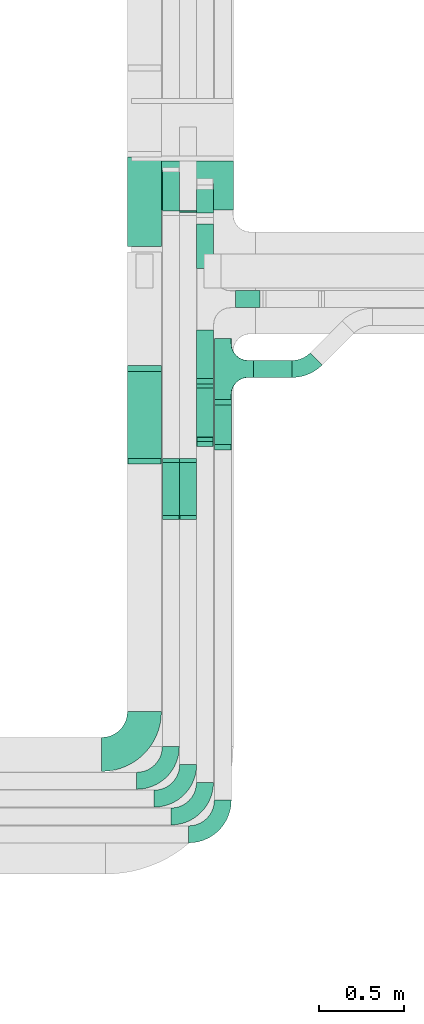
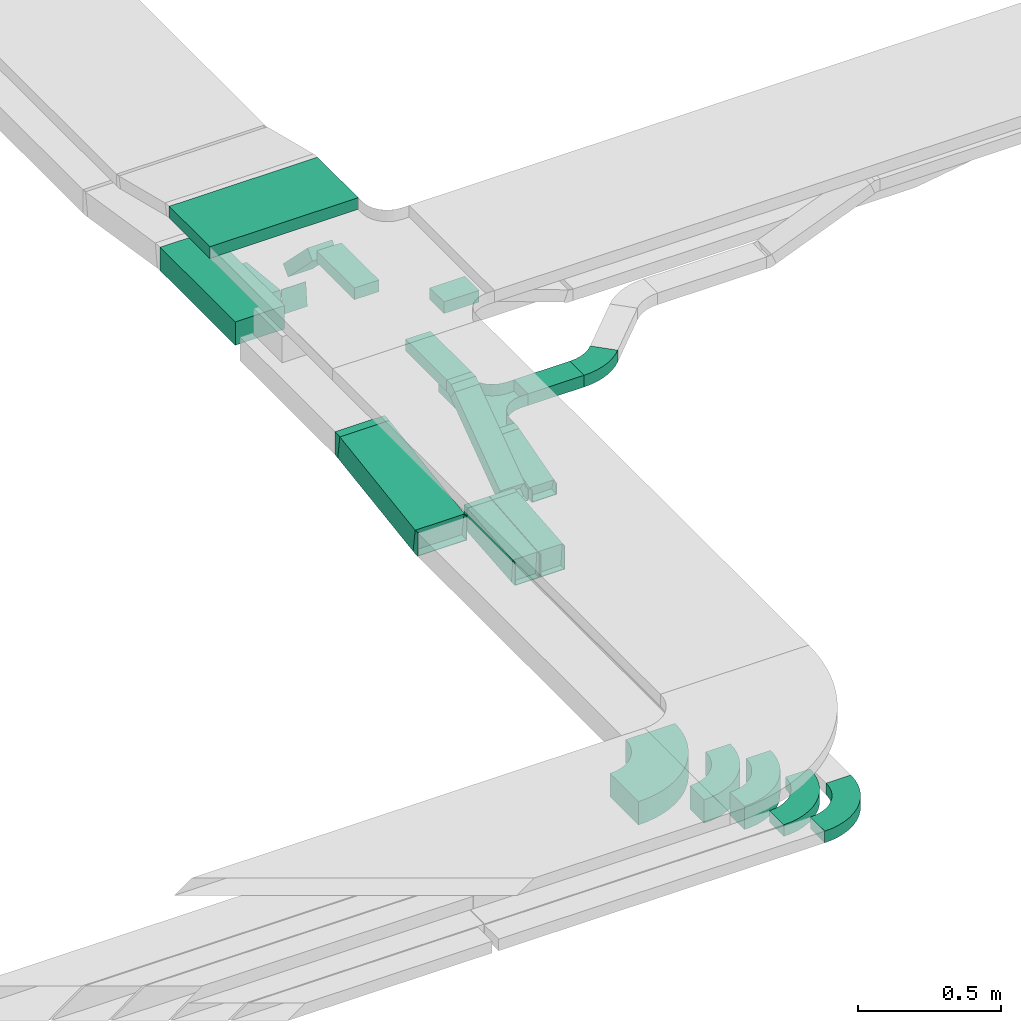
# One storey, part 22 of 28: 17 flow fittings, 14 flow segments.
"""IFC2X3 building model written with IfcOpenShell, lengths in millimetres."""

from ifc_helpers import new_model, entity, si_unit, converted_unit, derived_unit, direction, frame, frame_2d, origin, origin_2d_with_axis, place, context, subcontext, project, spatial, polyline, circle_curve, parameter, trimmed, segment, composite_curve, rectangle, outline, extrude, faceted_brep, source, transform, mapped, material, type_object, type_shapes, element, save


model = new_model("IFC2X3")

# Units and contexts
model_context = context("Model", 3, precision=0.01, world=origin(), true_north=direction((6.12303176911189e-17, 1.0)))
body_context = subcontext(model_context, "Body", "Model", "MODEL_VIEW")
ifc_project = project(units=[si_unit("LENGTHUNIT", "METRE", prefix="MILLI"), si_unit("AREAUNIT", "SQUARE_METRE"), si_unit("VOLUMEUNIT", "CUBIC_METRE"), converted_unit("PLANEANGLEUNIT", "DEGREE", entity("IfcRatioMeasure", 0.0174532925199433), si_unit("PLANEANGLEUNIT", "RADIAN"), dimensions=[0, 0, 0, 0, 0, 0, 0]), si_unit("MASSUNIT", "GRAM", prefix="KILO"), derived_unit("MASSDENSITYUNIT", [(si_unit("MASSUNIT", "GRAM", prefix="KILO"), 1), (si_unit("LENGTHUNIT", "METRE"), -3)]), derived_unit("MOMENTOFINERTIAUNIT", [(si_unit("LENGTHUNIT", "METRE"), 4)]), si_unit("TIMEUNIT", "SECOND"), si_unit("FREQUENCYUNIT", "HERTZ"), si_unit("THERMODYNAMICTEMPERATUREUNIT", "DEGREE_CELSIUS"), derived_unit("THERMALTRANSMITTANCEUNIT", [(si_unit("MASSUNIT", "GRAM", prefix="KILO"), 1), (si_unit("THERMODYNAMICTEMPERATUREUNIT", "KELVIN"), -1), (si_unit("TIMEUNIT", "SECOND"), -3)]), derived_unit("VOLUMETRICFLOWRATEUNIT", [(si_unit("LENGTHUNIT", "METRE"), 3), (si_unit("TIMEUNIT", "SECOND"), -1)]), derived_unit("MASSFLOWRATEUNIT", [(si_unit("MASSUNIT", "GRAM", prefix="KILO"), 1), (si_unit("TIMEUNIT", "SECOND"), -1)]), derived_unit("ROTATIONALFREQUENCYUNIT", [(si_unit("TIMEUNIT", "SECOND"), -1)]), si_unit("ELECTRICCURRENTUNIT", "AMPERE"), si_unit("ELECTRICVOLTAGEUNIT", "VOLT"), si_unit("POWERUNIT", "WATT"), si_unit("FORCEUNIT", "NEWTON", prefix="KILO"), si_unit("ILLUMINANCEUNIT", "LUX"), si_unit("LUMINOUSFLUXUNIT", "LUMEN"), si_unit("LUMINOUSINTENSITYUNIT", "CANDELA"), derived_unit("USERDEFINED", [(si_unit("MASSUNIT", "GRAM", prefix="KILO"), -1), (si_unit("LENGTHUNIT", "METRE"), -2), (si_unit("TIMEUNIT", "SECOND"), 3), (si_unit("LUMINOUSFLUXUNIT", "LUMEN"), 1)]), derived_unit("LINEARVELOCITYUNIT", [(si_unit("LENGTHUNIT", "METRE"), 1), (si_unit("TIMEUNIT", "SECOND"), -1)]), si_unit("PRESSUREUNIT", "PASCAL"), derived_unit("USERDEFINED", [(si_unit("LENGTHUNIT", "METRE"), -2), (si_unit("MASSUNIT", "GRAM", prefix="KILO"), 1), (si_unit("TIMEUNIT", "SECOND"), -2)]), derived_unit("LINEARFORCEUNIT", [(si_unit("MASSUNIT", "GRAM", prefix="KILO"), 1), (si_unit("LENGTHUNIT", "METRE"), 1), (si_unit("TIMEUNIT", "SECOND"), -2), (si_unit("LENGTHUNIT", "METRE"), -1)]), derived_unit("PLANARFORCEUNIT", [(si_unit("MASSUNIT", "GRAM", prefix="KILO"), 1), (si_unit("LENGTHUNIT", "METRE"), 1), (si_unit("TIMEUNIT", "SECOND"), -2), (si_unit("LENGTHUNIT", "METRE"), -2)])], contexts=[model_context])

# Site, building, storey
site_placement = place(None, origin())
site = spatial("IfcSite", under=ifc_project, at=site_placement, CompositionType="ELEMENT")
building_placement = place(site_placement, origin())
building = spatial("IfcBuilding", under=site, at=building_placement, CompositionType="ELEMENT")
storey_placement = place(building_placement, frame((0.0, 0.0, 4200.0)))
storey = spatial("IfcBuildingStorey", under=building, at=storey_placement, CompositionType="ELEMENT", Elevation=4200.0)

# Flow segments
cable_carrier_segment_type = type_object("IfcCableCarrierSegmentType", PredefinedType="CABLETRAYSEGMENT")
flow_segment_1_placement = place(storey_placement, frame((61982.18, 7730.19, 2504.48)))
element("IfcFlowSegment", 1, at=flow_segment_1_placement, inside=storey, type_object=cable_carrier_segment_type, context=body_context, shape_type="SweptSolid", body=[
    extrude(rectangle(XDim=49.9999999999994, YDim=255.01050846726, at=frame_2d((0.0, 0.0), x_axis=(0.0, 1.0))), frame((0.0, 129.46, 59.18), z_axis=(1.0, 0.0, 0.0), x_axis=(0.0, 0.961261695938266, 0.275637355817185)), (0.0, 0.0, 1.0), 99.9999999999945),
])
flow_segment_2_placement = place(storey_placement, frame((61494.03, 9123.32, 2859.5)))
element("IfcFlowSegment", 2, at=flow_segment_2_placement, inside=storey, type_object=cable_carrier_segment_type, context=body_context, shape_type="SweptSolid", body=[
    extrude(rectangle(XDim=285.765874456354, YDim=600.000000000002, at=origin_2d_with_axis()), frame((300.0, 142.88, 0.0), z_axis=(0.0, 0.0, 1.0), x_axis=(0.0, 1.0, 0.0)), (0.0, 0.0, 1.0), 49.9999999999995),
])
flow_segment_3_placement = place(storey_placement, frame((61878.34, 8130.36, 2757.63)))
element("IfcFlowSegment", 3, at=flow_segment_3_placement, inside=storey, type_object=cable_carrier_segment_type, context=body_context, shape_type="SweptSolid", body=[
    extrude(rectangle(XDim=287.085953827233, YDim=99.9999999999946, at=origin_2d_with_axis()), frame((50.0, 143.54, 0.0), z_axis=(0.0, -4.75296948219352e-07, 1.0), x_axis=(0.0, -1.0, -4.75296948219352e-07)), (0.0, 0.0, 1.0), 49.9999999999943),
])
flow_segment_4_placement = place(storey_placement, frame((61878.34, 7756.7, 2518.22)))
element("IfcFlowSegment", 4, at=flow_segment_4_placement, inside=storey, type_object=cable_carrier_segment_type, context=body_context, shape_type="SweptSolid", body=[
    extrude(rectangle(XDim=50.0000000000008, YDim=392.571805962097, at=frame_2d((0.0, 0.0), x_axis=(0.0, 1.0))), frame((0.0, 173.49, 135.6), z_axis=(1.0, 0.0, 0.0), x_axis=(0.0, -0.809016994374955, -0.587785252292463)), (0.0, 0.0, 1.0), 99.9999999999946),
])
flow_segment_5_placement = place(storey_placement, frame((61878.34, 9070.35, 2573.67)))
element("IfcFlowSegment", 5, at=flow_segment_5_placement, inside=storey, type_object=cable_carrier_segment_type, context=body_context, shape_type="SweptSolid", body=[
    extrude(rectangle(XDim=50.0000000000003, YDim=242.742091415324, at=frame_2d((0.0, 0.0), x_axis=(0.0, 1.0))), frame((0.0, 103.5, 103.5), z_axis=(1.0, 0.0, 0.0), x_axis=(0.0, -0.707106781186556, 0.707106781186539)), (0.0, 0.0, 1.0), 99.9999999999946),
])
flow_segment_6_placement = place(storey_placement, frame((61878.34, 8777.45, 2757.63)))
element("IfcFlowSegment", 6, at=flow_segment_6_placement, inside=storey, type_object=cable_carrier_segment_type, context=body_context, shape_type="SweptSolid", body=[
    extrude(rectangle(XDim=263.151349409973, YDim=99.9999999999946, at=origin_2d_with_axis()), frame((50.0, 131.58, 0.0), z_axis=(0.0, 5.18526979960657e-07, 1.0), x_axis=(0.0, 1.0, -5.18526979960657e-07)), (0.0, 0.0, 1.0), 49.9999999999932),
])
flow_segment_7_placement = place(storey_placement, frame((62108.34, 8547.45, 2757.63)))
element("IfcFlowSegment", 7, at=flow_segment_7_placement, inside=storey, type_object=cable_carrier_segment_type, context=body_context, shape_type="SweptSolid", body=[
    extrude(rectangle(XDim=142.246356724546, YDim=100.000000000001, at=origin_2d_with_axis()), frame((71.12, 50.0, 0.0)), (0.0, 0.0, 1.0), 49.9999999999995),
])
flow_segment_8_placement = place(storey_placement, frame((61778.68, 9106.66, 2529.62)))
element("IfcFlowSegment", 8, at=flow_segment_8_placement, inside=storey, type_object=cable_carrier_segment_type, context=body_context, shape_type="SweptSolid", body=[
    extrude(rectangle(XDim=2.73678962123566, YDim=99.9999999999946, at=origin_2d_with_axis()), frame((50.0, 1.36, 0.14), z_axis=(0.0, 0.10452846326773, 0.994521895368265), x_axis=(0.0, -0.994521895368265, 0.10452846326773)), (0.0, 0.0, 1.0), 100.000000000001),
])
flow_segment_9_placement = place(storey_placement, frame((61778.68, 7317.31, 2501.09)))
element("IfcFlowSegment", 9, at=flow_segment_9_placement, inside=storey, type_object=cable_carrier_segment_type, context=body_context, shape_type="SweptSolid", body=[
    extrude(rectangle(XDim=99.9999999999994, YDim=99.9999999999946, at=frame_2d((0.0, 0.0), x_axis=(0.0, 1.0))), frame((50.0, 4.53, 49.79), z_axis=(0.0, 0.995893162071827, 0.0905362343958401), x_axis=(-1.0, 0.0, 0.0)), (0.0, 0.0, 1.0), 319.917187827381),
])
flow_segment_10_placement = place(storey_placement, frame((61676.28, 9106.67, 2504.79)))
element("IfcFlowSegment", 10, at=flow_segment_10_placement, inside=storey, type_object=cable_carrier_segment_type, context=body_context, shape_type="SweptSolid", body=[
    extrude(rectangle(XDim=100.0, YDim=99.9999999999946, at=origin_2d_with_axis()), frame((50.0, 5.23, 74.84), z_axis=(0.0, 0.994521895368247, -0.104528463267908), x_axis=(0.0, 0.104528463267908, 0.994521895368247)), (0.0, 0.0, 1.0), 240.288708176998),
])
flow_segment_11_placement = place(storey_placement, frame((61676.28, 7317.3, 2501.09)))
element("IfcFlowSegment", 11, at=flow_segment_11_placement, inside=storey, type_object=cable_carrier_segment_type, context=body_context, shape_type="SweptSolid", body=[
    extrude(rectangle(XDim=99.9999999999994, YDim=99.9999999999946, at=frame_2d((0.0, 0.0), x_axis=(0.0, 1.0))), frame((50.0, 4.53, 49.79), z_axis=(0.0, 0.995893162071827, 0.0905362343958401), x_axis=(-1.0, 0.0, 0.0)), (0.0, 0.0, 1.0), 319.925697831031),
])
flow_segment_12_placement = place(storey_placement, frame((61471.18, 7645.64, 2502.44)))
element("IfcFlowSegment", 12, at=flow_segment_12_placement, inside=storey, type_object=cable_carrier_segment_type, context=body_context, shape_type="SweptSolid", body=[
    extrude(rectangle(XDim=99.9999999999998, YDim=533.962924663429, at=frame_2d((0.0, 0.0), x_axis=(0.0, 1.0))), frame((0.0, 271.44, 88.86), z_axis=(1.0, 0.0, 0.0), x_axis=(0.0, 0.989044291278135, 0.147619070211579)), (0.0, 0.0, 1.0), 200.000000000006),
])
flow_segment_13_placement = place(storey_placement, frame((61471.18, 8906.28, 2627.67)))
element("IfcFlowSegment", 13, at=flow_segment_13_placement, inside=storey, type_object=cable_carrier_segment_type, context=body_context, shape_type="SweptSolid", body=[
    extrude(rectangle(XDim=526.736320783405, YDim=200.000000000007, at=origin_2d_with_axis()), frame((100.0, 263.37, 0.0), z_axis=(0.0, 0.0, 1.0), x_axis=(0.0, -1.0, 0.0)), (0.0, 0.0, 1.0), 100.000000000002),
])
flow_segment_14_placement = place(storey_placement, frame((62212.18, 8137.18, 2577.31)))
element("IfcFlowSegment", 14, at=flow_segment_14_placement, inside=storey, type_object=cable_carrier_segment_type, context=body_context, shape_type="SweptSolid", body=[
    extrude(rectangle(XDim=226.520887797976, YDim=99.9999999999989, at=origin_2d_with_axis()), frame((113.26, 50.0, 0.0)), (0.0, 0.0, 1.0), 49.9999999999995),
])

# Flow fittings
ifc_material = material()
cable_carrier_fitting_type_1 = type_object("IfcCableCarrierFittingType", PredefinedType="NOTDEFINED", material=ifc_material)
shared_shape_1 = source(origin(), body_context, "Body", "Brep", [
    faceted_brep([(-53.41, -124.12, 25.0), (-50.0, -150.0, 25.0), (-50.0, -180.0, 25.0), (-49.2, -180.0, 25.0), (-49.2, -150.0, 25.0), (-52.63, -123.91, 25.0), (-62.7, -99.6, 25.0), (-78.72, -78.72, 25.0), (-99.6, -62.7, 25.0), (-123.91, -52.63, 25.0), (-150.0, -49.2, 25.0), (-180.0, -49.2, 25.0), (-180.0, -50.0, 25.0), (-150.0, -50.0, 25.0), (-124.12, -53.41, 25.0), (-100.0, -63.4, 25.0), (-79.29, -79.29, 25.0), (-63.4, -100.0, 25.0), (180.0, -50.0, 25.0), (180.0, -49.2, 25.0), (150.0, -49.2, 25.0), (123.91, -52.63, 25.0), (99.6, -62.7, 25.0), (78.72, -78.72, 25.0), (62.7, -99.6, 25.0), (52.63, -123.91, 25.0), (49.2, -150.0, 25.0), (49.2, -180.0, 25.0), (50.0, -180.0, 25.0), (50.0, -150.0, 25.0), (53.41, -124.12, 25.0), (63.4, -100.0, 25.0), (79.29, -79.29, 25.0), (100.0, -63.4, 25.0), (124.12, -53.41, 25.0), (150.0, -50.0, 25.0), (180.0, 49.2, 25.0), (180.0, 50.0, 25.0), (-180.0, 50.0, 25.0), (-180.0, 49.2, 25.0), (-180.0, -50.0, -25.0), (-180.0, 50.0, -25.0), (180.0, 50.0, -25.0), (180.0, -50.0, -25.0), (150.0, -50.0, -25.0), (124.12, -53.41, -25.0), (100.0, -63.4, -25.0), (79.29, -79.29, -25.0), (63.4, -100.0, -25.0), (53.41, -124.12, -25.0), (50.0, -150.0, -25.0), (50.0, -180.0, -25.0), (-50.0, -180.0, -25.0), (-50.0, -150.0, -25.0), (-53.41, -124.12, -25.0), (-63.4, -100.0, -25.0), (-79.29, -79.29, -25.0), (-100.0, -63.4, -25.0), (-124.12, -53.41, -25.0), (-150.0, -50.0, -25.0), (-50.0, -150.0, -24.2), (49.2, -180.0, -24.2), (-49.2, -180.0, -24.2), (-49.2, -150.0, -24.2), (-150.0, -49.2, -24.2), (-180.0, -49.2, -24.2), (180.0, -49.2, -24.2), (150.0, -49.2, -24.2), (-180.0, 49.2, -24.2), (-150.0, -50.0, -24.2), (150.0, -50.0, -24.2), (180.0, 49.2, -24.2), (49.2, -150.0, -24.2), (50.0, -150.0, -24.2), (-123.91, -52.63, -24.2), (-99.6, -62.7, -24.2), (-78.72, -78.72, -24.2), (-62.7, -99.6, -24.2), (-52.63, -123.91, -24.2), (52.63, -123.91, -24.2), (62.7, -99.6, -24.2), (78.72, -78.72, -24.2), (99.6, -62.7, -24.2), (123.91, -52.63, -24.2)], [[[0, 1, 2, 3, 4, 5, 6, 7, 8, 9, 10, 11, 12, 13, 14, 15, 16, 17]], [[18, 19, 20, 21, 22, 23, 24, 25, 26, 27, 28, 29, 30, 31, 32, 33, 34, 35]], [[36, 37, 38, 39]], [[40, 41, 42, 43, 44, 45, 46, 47, 48, 49, 50, 51, 52, 53, 54, 55, 56, 57, 58, 59]], [[2, 1, 60, 53, 52]], [[3, 2, 52, 51, 28, 27, 61, 62]], [[4, 3, 62, 63]], [[11, 10, 64, 65]], [[20, 19, 66, 67]], [[39, 38, 41, 40, 12, 11, 65, 68]], [[13, 12, 40, 59, 69]], [[18, 35, 70, 44, 43]], [[19, 18, 43, 42, 37, 36, 71, 66]], [[27, 26, 72, 61]], [[29, 28, 51, 50, 73]], [[38, 37, 42, 41]], [[36, 39, 68, 71]], [[68, 65, 64, 74, 75, 76, 77, 78, 63, 62, 61, 72, 79, 80, 81, 82, 83, 67, 66, 71]], [[14, 13, 69, 59, 58]], [[58, 57, 15, 14]], [[15, 57, 56, 16]], [[0, 17, 55, 54]], [[0, 54, 53, 60, 1]], [[55, 17, 16, 56]], [[5, 4, 63, 78]], [[6, 5, 78, 77]], [[7, 6, 77, 76]], [[8, 7, 76, 75]], [[9, 8, 75, 74]], [[10, 9, 74, 64]], [[21, 20, 67, 83]], [[22, 21, 83, 82]], [[23, 22, 82, 81]], [[81, 80, 24, 23]], [[24, 80, 79, 25]], [[79, 72, 26, 25]], [[30, 29, 73, 50, 49]], [[31, 30, 49, 48]], [[31, 48, 47, 32]], [[33, 32, 47, 46]], [[45, 34, 33, 46]], [[34, 45, 44, 70, 35]]]),
])
type_shapes(cable_carrier_fitting_type_1, [shared_shape_1])
flow_fitting_1_placement = place(storey_placement, frame((62032.18, 8187.18, 2602.31), z_axis=(0.0, 0.0, 1.0), x_axis=(0.0, 1.0, 0.0)))
element("IfcFlowFitting", 15, at=flow_fitting_1_placement, inside=storey, type_object=cable_carrier_fitting_type_1, material=ifc_material, Name="470_DKC_S5_T", context=body_context, shape_type="MappedRepresentation", body=[
    mapped(shared_shape_1, transform((0.0, 0.0, 0.0), scale=1.0)),
])
cable_carrier_fitting_type_2 = type_object("IfcCableCarrierFittingType", PredefinedType="NOTDEFINED", material=ifc_material)
shared_shape_2 = source(origin(), body_context, "Body", "Brep", [
    faceted_brep([(-12.73, -25.0, 50.0), (-12.73, 25.0, 50.0), (-12.73, 25.0, 47.46), (-12.73, -22.46, 47.46), (-12.73, -22.46, -47.46), (-12.73, 25.0, -47.46), (-12.73, 25.0, -50.0), (-12.73, -25.0, -50.0), (19.13, -20.52, 50.0), (19.13, -20.52, -50.0), (5.35, 27.54, -50.0), (5.35, 27.54, -47.46), (18.43, -18.08, -47.46), (18.43, -18.08, 47.46), (5.35, 27.54, 47.46), (5.35, 27.54, 50.0), (3.51, -25.0, 50.0), (-3.51, 25.0, 50.0), (-3.51, 25.0, 47.46), (3.16, -22.46, 47.46), (3.16, -22.46, -47.46), (-3.51, 25.0, -47.46), (-3.51, 25.0, -50.0), (3.51, -25.0, -50.0)], [[[0, 1, 2, 3, 4, 5, 6, 7]], [[8, 9, 10, 11, 12, 13, 14, 15]], [[1, 0, 16, 8, 15, 17]], [[2, 1, 17, 18]], [[3, 2, 18, 14, 13, 19]], [[4, 3, 19, 20]], [[5, 4, 20, 12, 11, 21]], [[6, 5, 21, 22]], [[7, 6, 22, 10, 9, 23]], [[0, 7, 23, 16]], [[18, 17, 15, 14]], [[20, 19, 13, 12]], [[22, 21, 11, 10]], [[16, 23, 9, 8]]]),
])
type_shapes(cable_carrier_fitting_type_2, [shared_shape_2])
for number, where, z_axis, x_axis in (
    (16, (62032.18, 7994.45, 2602.31), (1.0, 0.0, 0.0), (0.0, -1.0, 0.0)),
    (17, (62032.18, 7724.85, 2525.0), (-1.0, 0.0, 0.0), (0.0, -0.96126169593834, -0.275637355816927)),
):
    element("IfcFlowFitting", number, at=place(storey_placement, frame(where, z_axis=z_axis, x_axis=x_axis)), inside=storey, type_object=cable_carrier_fitting_type_2, material=ifc_material, context=body_context, shape_type="MappedRepresentation", body=[
        mapped(shared_shape_2, transform((0.0, 0.0, 0.0), scale=1.0)),
    ])
cable_carrier_fitting_type_3 = type_object("IfcCableCarrierFittingType", PredefinedType="NOTDEFINED", material=ifc_material)
shared_shape_3 = source(origin(), body_context, "Body", "Brep", [
    faceted_brep([(-22.87, -25.0, 50.0), (-22.87, 25.0, 50.0), (-22.87, 25.0, 47.46), (-22.87, -22.46, 47.46), (-22.87, -22.46, -47.46), (-22.87, 25.0, -47.46), (-22.87, 25.0, -50.0), (-22.87, -25.0, -50.0), (33.2, -6.78, 50.0), (33.2, -6.78, -50.0), (3.81, 33.67, -50.0), (3.81, 33.67, -47.46), (31.7, -4.73, -47.46), (31.7, -4.73, 47.46), (3.81, 33.67, 47.46), (3.81, 33.67, 50.0), (8.12, -25.0, 50.0), (-8.12, 25.0, 50.0), (-8.12, 25.0, 47.46), (7.3, -22.46, 47.46), (7.3, -22.46, -47.46), (-8.12, 25.0, -47.46), (-8.12, 25.0, -50.0), (8.12, -25.0, -50.0)], [[[0, 1, 2, 3, 4, 5, 6, 7]], [[8, 9, 10, 11, 12, 13, 14, 15]], [[1, 0, 16, 8, 15, 17]], [[2, 1, 17, 18]], [[3, 2, 18, 14, 13, 19]], [[4, 3, 19, 20]], [[5, 4, 20, 12, 11, 21]], [[6, 5, 21, 22]], [[7, 6, 22, 10, 9, 23]], [[0, 7, 23, 16]], [[18, 17, 15, 14]], [[20, 19, 13, 12]], [[22, 21, 11, 10]], [[16, 23, 9, 8]]]),
])
type_shapes(cable_carrier_fitting_type_3, [shared_shape_3])
flow_fitting_2_placement = place(storey_placement, frame((61928.34, 8107.49, 2782.63), z_axis=(1.0, 0.0, 0.0), x_axis=(0.0, -1.0, 0.0)))
element("IfcFlowFitting", 18, at=flow_fitting_2_placement, inside=storey, type_object=cable_carrier_fitting_type_3, material=ifc_material, context=body_context, shape_type="MappedRepresentation", body=[
    mapped(shared_shape_3, transform((0.0, 0.0, 0.0), scale=1.0)),
])
cable_carrier_fitting_type_4 = type_object("IfcCableCarrierFittingType", PredefinedType="NOTDEFINED", material=ifc_material)
type_shapes(cable_carrier_fitting_type_4, [shared_shape_3])
flow_fitting_3_placement = place(storey_placement, frame((61928.34, 7752.89, 2525.0), z_axis=(-0.999999701412861, 0.000454223081767953, -0.000625184437606124), x_axis=(0.0, -0.809016994374954, -0.587785252292465)))
element("IfcFlowFitting", 19, at=flow_fitting_3_placement, inside=storey, type_object=cable_carrier_fitting_type_4, material=ifc_material, context=body_context, shape_type="MappedRepresentation", body=[
    mapped(shared_shape_3, transform((0.0, 0.0, 0.0), scale=1.0)),
])
cable_carrier_fitting_type_5 = type_object("IfcCableCarrierFittingType", PredefinedType="NOTDEFINED", material=ifc_material)
shared_shape_4 = source(origin(), body_context, "Body", "Brep", [
    faceted_brep([(-9.76, -50.0, 50.0), (-9.76, 50.0, 50.0), (-9.76, 50.0, 47.46), (-9.76, -47.46, 47.46), (-9.76, -47.46, -47.46), (-9.76, 50.0, -47.46), (-9.76, 50.0, -50.0), (-9.76, -50.0, -50.0), (14.25, -48.91, 50.0), (14.25, -48.91, -50.0), (5.2, 50.68, -50.0), (5.2, 50.68, -47.46), (14.02, -46.38, -47.46), (14.02, -46.38, 47.46), (5.2, 50.68, 47.46), (5.2, 50.68, 50.0), (2.27, -50.0, 50.0), (-2.27, 50.0, 50.0), (-2.27, 50.0, 47.46), (2.15, -47.46, 47.46), (2.15, -47.46, -47.46), (-2.27, 50.0, -47.46), (-2.27, 50.0, -50.0), (2.27, -50.0, -50.0)], [[[0, 1, 2, 3, 4, 5, 6, 7]], [[8, 9, 10, 11, 12, 13, 14, 15]], [[1, 0, 16, 8, 15, 17]], [[2, 1, 17, 18]], [[3, 2, 18, 14, 13, 19]], [[4, 3, 19, 20]], [[5, 4, 20, 12, 11, 21]], [[6, 5, 21, 22]], [[7, 6, 22, 10, 9, 23]], [[0, 7, 23, 16]], [[18, 17, 15, 14]], [[20, 19, 13, 12]], [[22, 21, 11, 10]], [[16, 23, 9, 8]]]),
])
type_shapes(cable_carrier_fitting_type_5, [shared_shape_4])
for number, where, z_axis, x_axis in (
    (20, (61828.68, 7312.11, 2550.0), (1.0, 0.0, 0.0), (0.0, 1.0, 0.0)),
    (21, (61828.68, 7650.16, 2580.73), (-1.0, 0.0, 0.0), (0.0, 0.995893162071827, 0.090536234395836)),
    (22, (61726.28, 7650.16, 2580.73), (-1.0, 0.0, 0.0), (0.0, 0.995893162071827, 0.0905362343958338)),
    (23, (61726.28, 7312.1, 2550.0), (-1.0, 0.0, 0.0), (0.0, -0.995893162071818, -0.09053623439593)),
):
    element("IfcFlowFitting", number, at=place(storey_placement, frame(where, z_axis=z_axis, x_axis=x_axis)), inside=storey, type_object=cable_carrier_fitting_type_5, material=ifc_material, context=body_context, shape_type="MappedRepresentation", body=[
        mapped(shared_shape_4, transform((0.0, 0.0, 0.0), scale=1.0)),
    ])
cable_carrier_fitting_type_6 = type_object("IfcCableCarrierFittingType", PredefinedType="NOTDEFINED", material=ifc_material)
shared_shape_5 = source(origin(), body_context, "Body", "Brep", [
    faceted_brep([(-12.79, -50.0, 100.0), (-12.79, 50.0, 100.0), (-12.79, 50.0, 97.46), (-12.79, -47.46, 97.46), (-12.79, -47.46, -97.46), (-12.79, 50.0, -97.46), (-12.79, 50.0, -100.0), (-12.79, -50.0, -100.0), (20.03, -47.56, 100.0), (20.03, -47.56, -100.0), (5.27, 51.34, -100.0), (5.27, 51.34, -97.46), (19.66, -45.05, -97.46), (19.66, -45.05, 97.46), (5.27, 51.34, 97.46), (5.27, 51.34, 100.0), (3.71, -50.0, 100.0), (-3.71, 50.0, 100.0), (-3.71, 50.0, 97.46), (3.52, -47.46, 97.46), (3.52, -47.46, -97.46), (-3.71, 50.0, -97.46), (-3.71, 50.0, -100.0), (3.71, -50.0, -100.0)], [[[0, 1, 2, 3, 4, 5, 6, 7]], [[8, 9, 10, 11, 12, 13, 14, 15]], [[1, 0, 16, 8, 15, 17]], [[2, 1, 17, 18]], [[3, 2, 18, 14, 13, 19]], [[4, 3, 19, 20]], [[5, 4, 20, 12, 11, 21]], [[6, 5, 21, 22]], [[7, 6, 22, 10, 9, 23]], [[0, 7, 23, 16]], [[18, 17, 15, 14]], [[20, 19, 13, 12]], [[22, 21, 11, 10]], [[16, 23, 9, 8]]]),
])
type_shapes(cable_carrier_fitting_type_6, [shared_shape_5])
for number, where, z_axis, x_axis in (
    (24, (61571.18, 7640.37, 2550.0), (1.0, 0.0, 0.0), (0.0, 1.0, 0.0)),
    (25, (61571.18, 8193.79, 2632.6), (1.0, 0.0, 0.0), (0.0, -1.0, 0.0)),
):
    element("IfcFlowFitting", number, at=place(storey_placement, frame(where, z_axis=z_axis, x_axis=x_axis)), inside=storey, type_object=cable_carrier_fitting_type_6, material=ifc_material, context=body_context, shape_type="MappedRepresentation", body=[
        mapped(shared_shape_5, transform((0.0, 0.0, 0.0), scale=1.0)),
    ])
cable_carrier_fitting_type_7 = type_object("IfcCableCarrierFittingType", Name="470_DKC_S5_Variable Angle Elbow 0-45:-", PredefinedType="NOTDEFINED", material=ifc_material)
shared_shape_6 = source(origin(), body_context, "Body", "SweptSolid", [
    extrude(outline(composite_curve([segment(polyline([(-125.75, -225.25), (-124.75, -225.25)]), True, "CONTINUOUS"), segment(trimmed(circle_curve(frame_2d((-124.75, 124.75), x_axis=(0.0, -1.0)), 350.0), [parameter(0.0)], [parameter(90.0000000000001)], True, "PARAMETER"), True, "CONTINUOUS"), segment(polyline([(225.25, 124.75), (225.25, 125.75)]), True, "CONTINUOUS"), segment(polyline([(225.25, 125.75), (25.25, 125.75)]), True, "CONTINUOUS"), segment(polyline([(25.25, 125.75), (25.25, 124.75)]), True, "CONTINUOUS"), segment(trimmed(circle_curve(frame_2d((-124.75, 124.75), x_axis=(0.0, -1.0)), 150.0), [parameter(0.0)], [parameter(90.0000000000001)], True, "PARAMETER"), False, "CONTINUOUS"), segment(polyline([(-124.75, -25.25), (-125.75, -25.25)]), True, "CONTINUOUS"), segment(polyline([(-125.75, -25.25), (-125.75, -225.25)]), True, "CONTINUOUS")], self_intersect=False)), frame((-125.25, 125.25, -50.0)), (0.0, 0.0, 1.0), 100.0),
])
type_shapes(cable_carrier_fitting_type_7, [shared_shape_6])
flow_fitting_4_placement = place(storey_placement, frame((61571.18, 5920.37, 2550.0)))
element("IfcFlowFitting", 26, at=flow_fitting_4_placement, inside=storey, type_object=cable_carrier_fitting_type_7, material=ifc_material, Name="470_DKC_S5_Variable Angle Elbow 0-45:-", ObjectType="470_DKC_S5_Variable Angle Elbow 0-45:-", context=body_context, shape_type="MappedRepresentation", body=[
    mapped(shared_shape_6, transform((0.0, 0.0, 0.0), scale=1.0)),
])
cable_carrier_fitting_type_8 = type_object("IfcCableCarrierFittingType", Name="470_DKC_S5_Variable Angle Elbow 0-45:-", PredefinedType="NOTDEFINED", material=ifc_material)
shared_shape_7 = source(origin(), body_context, "Body", "SweptSolid", [
    extrude(outline(composite_curve([segment(polyline([(-100.75, -150.25), (-99.75, -150.25)]), True, "CONTINUOUS"), segment(trimmed(circle_curve(frame_2d((-99.75, 99.75), x_axis=(0.0, -1.0)), 250.0), [parameter(0.0)], [parameter(90.0000000000001)], True, "PARAMETER"), True, "CONTINUOUS"), segment(polyline([(150.25, 99.75), (150.25, 100.75)]), True, "CONTINUOUS"), segment(polyline([(150.25, 100.75), (50.25, 100.75)]), True, "CONTINUOUS"), segment(polyline([(50.25, 100.75), (50.25, 99.75)]), True, "CONTINUOUS"), segment(trimmed(circle_curve(frame_2d((-99.75, 99.75), x_axis=(0.0, -1.0)), 150.0), [parameter(0.0)], [parameter(90.0000000000001)], True, "PARAMETER"), False, "CONTINUOUS"), segment(polyline([(-99.75, -50.25), (-100.75, -50.25)]), True, "CONTINUOUS"), segment(polyline([(-100.75, -50.25), (-100.75, -150.25)]), True, "CONTINUOUS")], self_intersect=False)), frame((-100.25, 100.25, -25.0)), (0.0, 0.0, 1.0), 49.9999999999997),
])
type_shapes(cable_carrier_fitting_type_8, [shared_shape_7])
flow_fitting_5_placement = place(storey_placement, frame((62032.18, 5450.19, 2525.0)))
element("IfcFlowFitting", 27, at=flow_fitting_5_placement, inside=storey, type_object=cable_carrier_fitting_type_8, material=ifc_material, Name="470_DKC_S5_Variable Angle Elbow 0-45:-", ObjectType="470_DKC_S5_Variable Angle Elbow 0-45:-", context=body_context, shape_type="MappedRepresentation", body=[
    mapped(shared_shape_7, transform((0.0, 0.0, 0.0), scale=1.0)),
])
cable_carrier_fitting_type_9 = type_object("IfcCableCarrierFittingType", Name="470_DKC_S5_Variable Angle Elbow 0-45:-", PredefinedType="NOTDEFINED", material=ifc_material)
shared_shape_8 = source(origin(), body_context, "Body", "SweptSolid", [
    extrude(outline(composite_curve([segment(polyline([(-100.75, -150.25), (-99.75, -150.25)]), True, "CONTINUOUS"), segment(trimmed(circle_curve(frame_2d((-99.75, 99.75), x_axis=(0.0, -1.0)), 250.0), [parameter(0.0)], [parameter(90.0000000000001)], True, "PARAMETER"), True, "CONTINUOUS"), segment(polyline([(150.25, 99.75), (150.25, 100.75)]), True, "CONTINUOUS"), segment(polyline([(150.25, 100.75), (50.25, 100.75)]), True, "CONTINUOUS"), segment(polyline([(50.25, 100.75), (50.25, 99.75)]), True, "CONTINUOUS"), segment(trimmed(circle_curve(frame_2d((-99.75, 99.75), x_axis=(0.0, -1.0)), 150.0), [parameter(0.0)], [parameter(90.0000000000001)], True, "PARAMETER"), False, "CONTINUOUS"), segment(polyline([(-99.75, -50.25), (-100.75, -50.25)]), True, "CONTINUOUS"), segment(polyline([(-100.75, -50.25), (-100.75, -150.25)]), True, "CONTINUOUS")], self_intersect=False)), frame((-100.25, 100.25, -50.0)), (0.0, 0.0, 1.0), 100.0),
])
type_shapes(cable_carrier_fitting_type_9, [shared_shape_8])
for number, where, name in (
    (28, (61828.68, 5660.19, 2550.0), "470_DKC_S5_Variable Angle Elbow 0-45:-"),
    (29, (61726.28, 5765.19, 2550.0), "470_DKC_S5_Variable Angle Elbow 0-45:-"),
):
    element("IfcFlowFitting", number, at=place(storey_placement, frame(where)), inside=storey, type_object=cable_carrier_fitting_type_9, material=ifc_material, Name=name, ObjectType="470_DKC_S5_Variable Angle Elbow 0-45:-", context=body_context, shape_type="MappedRepresentation", body=[
        mapped(shared_shape_8, transform((0.0, 0.0, 0.0), scale=1.0)),
    ])
cable_carrier_fitting_type_10 = type_object("IfcCableCarrierFittingType", Name="470_DKC_S5_Variable Angle Elbow 0-45:-", PredefinedType="NOTDEFINED", material=ifc_material)
shared_shape_9 = source(origin(), body_context, "Body", "SweptSolid", [
    extrude(outline(composite_curve([segment(polyline([(-100.75, -150.2), (-99.75, -150.2)]), True, "CONTINUOUS"), segment(trimmed(circle_curve(frame_2d((-99.75, 99.8), x_axis=(0.0, -1.0)), 250.0), [parameter(0.0)], [parameter(89.9738905754284)], True, "PARAMETER"), True, "CONTINUOUS"), segment(polyline([(150.25, 99.68), (150.25, 100.68)]), True, "CONTINUOUS"), segment(polyline([(150.25, 100.68), (50.25, 100.73)]), True, "CONTINUOUS"), segment(polyline([(50.25, 100.73), (50.25, 99.73)]), True, "CONTINUOUS"), segment(trimmed(circle_curve(frame_2d((-99.75, 99.8), x_axis=(0.0, -1.0)), 150.0), [parameter(0.0)], [parameter(89.9738905754284)], True, "PARAMETER"), False, "CONTINUOUS"), segment(polyline([(-99.75, -50.2), (-100.75, -50.2)]), True, "CONTINUOUS"), segment(polyline([(-100.75, -50.2), (-100.75, -150.2)]), True, "CONTINUOUS")], self_intersect=False)), frame((-100.16, 100.2, -25.0)), (0.0, 0.0, 1.0), 49.9999999999997),
])
type_shapes(cable_carrier_fitting_type_10, [shared_shape_9])
flow_fitting_6_placement = place(storey_placement, frame((61927.34, 5555.2, 2525.0)))
element("IfcFlowFitting", 30, at=flow_fitting_6_placement, inside=storey, type_object=cable_carrier_fitting_type_10, material=ifc_material, Name="470_DKC_S5_Variable Angle Elbow 0-45:-", ObjectType="470_DKC_S5_Variable Angle Elbow 0-45:-", context=body_context, shape_type="MappedRepresentation", body=[
    mapped(shared_shape_9, transform((0.0, 0.0, 0.0), scale=1.0)),
])
cable_carrier_fitting_type_11 = type_object("IfcCableCarrierFittingType", Name="470_DKC_S5_Variable Angle Elbow 0-45:-", PredefinedType="NOTDEFINED", material=ifc_material)
shared_shape_10 = source(origin(), body_context, "Body", "SweptSolid", [
    extrude(outline(composite_curve([segment(polyline([(-71.64, -79.47), (-70.64, -79.47)]), True, "CONTINUOUS"), segment(trimmed(circle_curve(frame_2d((-70.64, 170.53), x_axis=(0.0, -1.0)), 250.0), [parameter(0.0)], [parameter(45.0)], True, "PARAMETER"), True, "CONTINUOUS"), segment(polyline([(106.14, -6.24), (106.85, -5.54)]), True, "CONTINUOUS"), segment(polyline([(106.85, -5.54), (36.14, 65.17)]), True, "CONTINUOUS"), segment(polyline([(36.14, 65.17), (35.43, 64.47)]), True, "CONTINUOUS"), segment(trimmed(circle_curve(frame_2d((-70.64, 170.53), x_axis=(0.0, -1.0)), 150.0), [parameter(0.0)], [parameter(45.0)], True, "PARAMETER"), False, "CONTINUOUS"), segment(polyline([(-70.64, 20.53), (-71.64, 20.53)]), True, "CONTINUOUS"), segment(polyline([(-71.64, 20.53), (-71.64, -79.47)]), True, "CONTINUOUS")], self_intersect=False)), frame((-12.21, 29.47, -25.0)), (0.0, 0.0, 1.0), 49.9999999999999),
])
type_shapes(cable_carrier_fitting_type_11, [shared_shape_10])
flow_fitting_7_placement = place(storey_placement, frame((62522.55, 8187.18, 2602.31)))
element("IfcFlowFitting", 31, at=flow_fitting_7_placement, inside=storey, type_object=cable_carrier_fitting_type_11, material=ifc_material, Name="470_DKC_S5_Variable Angle Elbow 0-45:-", ObjectType="470_DKC_S5_Variable Angle Elbow 0-45:-", context=body_context, shape_type="MappedRepresentation", body=[
    mapped(shared_shape_10, transform((0.0, 0.0, 0.0), scale=1.0)),
])

save(model, "model.ifc")
